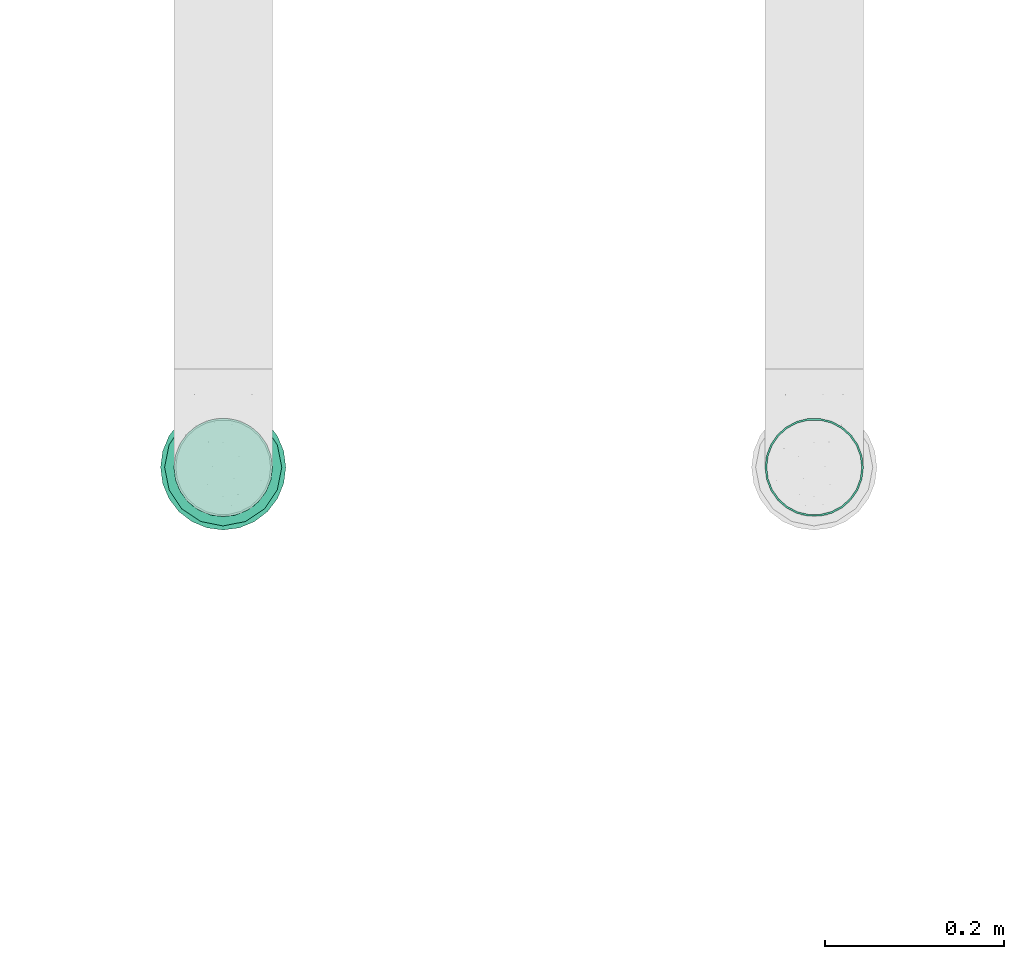
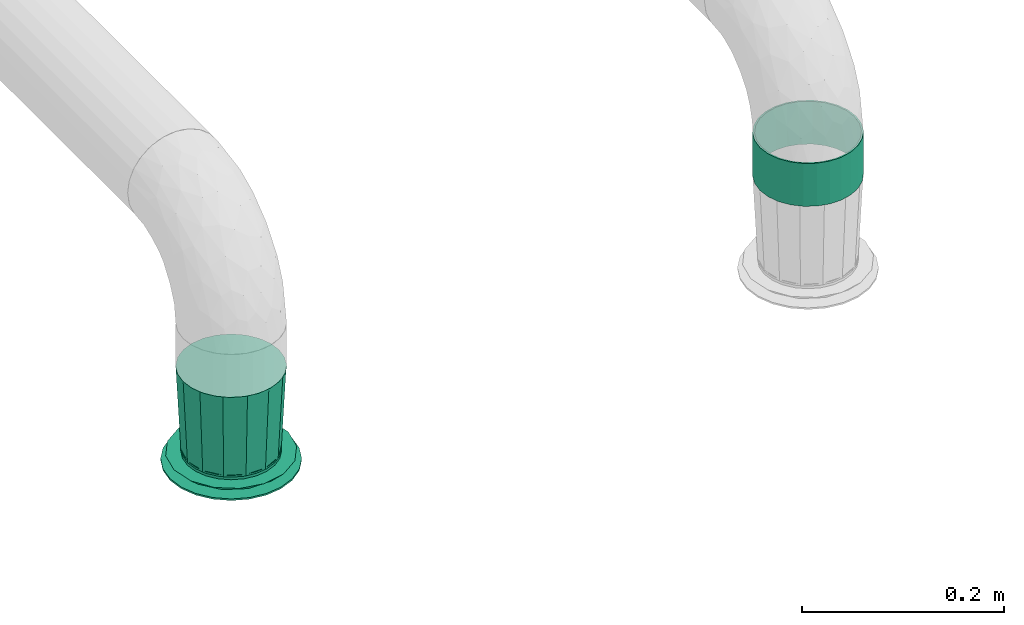
# One storey, part 48 of 115: 1 flow fitting, 1 flow segment, 1 flow terminal.
"""IFC2X3 building model written with IfcOpenShell, lengths in millimetres."""

from ifc_helpers import new_model, entity, si_unit, converted_unit, derived_unit, direction, frame, origin_with_axes, origin_2d_with_axis, place, context, subcontext, project, spatial, hollow_circle, extrude, open_shell, surface_model, source, transform, mapped, material, layer, layer_set, layer_usage, type_object, element, save


model = new_model("IFC2X3")

# Units and contexts
model_context = context("Model", 3, precision=1e-05, world=origin_with_axes(), true_north=direction((0.0, 1.0)))
body_context = subcontext(model_context, "Body", "Model", "MODEL_VIEW")
ifc_project = project(units=[si_unit("AREAUNIT", "SQUARE_METRE"), si_unit("VOLUMEUNIT", "CUBIC_METRE", prefix="DECI"), si_unit("TIMEUNIT", "SECOND"), si_unit("THERMODYNAMICTEMPERATUREUNIT", "DEGREE_CELSIUS"), si_unit("PRESSUREUNIT", "PASCAL"), si_unit("MASSUNIT", "GRAM", prefix="KILO"), si_unit("LENGTHUNIT", "METRE", prefix="MILLI"), si_unit("POWERUNIT", "WATT"), si_unit("ELECTRICCURRENTUNIT", "AMPERE"), si_unit("ELECTRICVOLTAGEUNIT", "VOLT"), derived_unit("VOLUMETRICFLOWRATEUNIT", [(si_unit("VOLUMEUNIT", "CUBIC_METRE", prefix="DECI"), 1), (si_unit("TIMEUNIT", "SECOND"), -1)]), derived_unit("LINEARVELOCITYUNIT", [(si_unit("LENGTHUNIT", "METRE"), 1), (si_unit("TIMEUNIT", "SECOND"), -1)]), derived_unit("MASSDENSITYUNIT", [(si_unit("MASSUNIT", "GRAM", prefix="KILO"), 1), (si_unit("VOLUMEUNIT", "CUBIC_METRE"), -1)]), converted_unit("PLANEANGLEUNIT", "DEGREE", entity("IfcRatioMeasure", 0.01745), si_unit("PLANEANGLEUNIT", "RADIAN"), dimensions=[0, 0, 0, 0, 0, 0, 0])], contexts=[model_context])

# Site, building, storey
site_placement = place(None, origin_with_axes())
site = spatial("IfcSite", under=ifc_project, at=site_placement, CompositionType="ELEMENT")
building_placement = place(site_placement, origin_with_axes())
building = spatial("IfcBuilding", under=site, at=building_placement, Name="mc-building", CompositionType="ELEMENT")
storey_placement = place(building_placement, frame((0.0, 0.0, 2950.0), z_axis=(0.0, 0.0, 1.0), x_axis=(1.0, 0.0, 0.0)))
storey = spatial("IfcBuildingStorey", under=building, at=storey_placement, Name="2. Korrus", CompositionType="ELEMENT", Elevation=2950.0)

# Flow terminal
air_terminal_type = type_object("IfcAirTerminalType", Name="100", PredefinedType="NOTDEFINED")
shared_shape_1 = source(origin_with_axes(), body_context, "Body", "SurfaceModel", [
    surface_model("IfcShellBasedSurfaceModel", [(11.2, 18.11733, -67.61481), (11.2, -18.11733, -67.61481), (11.2, 0.0, -70.0), (11.2, 67.61481, -18.11733), (11.2, 35.0, -60.62178), (11.2, 49.49747, -49.49747), (11.2, 60.62178, -35.0), (11.2, -67.61481, 18.11733), (11.2, -49.49747, -49.49747), (11.2, -67.61481, -18.11733), (11.2, -35.0, -60.62178), (11.2, -60.62178, -35.0), (11.2, -70.0, 0.0), (11.2, 18.11733, 67.61481), (11.2, 70.0, 0.0), (11.2, 67.61481, 18.11733), (11.2, 49.49747, 49.49747), (11.2, 60.62178, 35.0), (11.2, 35.0, 60.62178), (11.2, -49.49747, 49.49747), (11.2, -60.62178, 35.0), (11.2, -35.0, 60.62178), (11.2, -18.11733, 67.61481), (11.2, 0.0, 70.0), (9.2, 18.11733, 67.61481), (9.2, -67.61481, 18.11733), (9.2, 0.0, 70.0), (9.2, 49.49747, 49.49747), (9.2, 35.0, 60.62178), (9.2, 60.62178, 35.0), (9.2, 67.61481, 18.11733), (9.2, -35.0, 60.62178), (9.2, -49.49747, 49.49747), (9.2, -18.11733, 67.61481), (9.2, -60.62178, 35.0), (9.2, -67.61481, -18.11733), (9.2, -70.0, 0.0), (9.2, 67.61481, -18.11733), (9.2, 18.11733, -67.61481), (9.2, 49.49747, -49.49747), (9.2, 60.62178, -35.0), (9.2, 35.0, -60.62178), (9.2, -18.11733, -67.61481), (9.2, -49.49747, -49.49747), (9.2, -60.62178, -35.0), (9.2, -35.0, -60.62178), (9.2, 0.0, -70.0), (9.2, 70.0, 0.0), (9.2, 32.75, 0.0), (9.2, -16.375, 28.36233), (9.2, -28.36233, 16.375), (9.2, 16.375, 28.36233), (9.2, 0.0, 32.75), (9.2, 28.36233, 16.375), (9.2, -32.75, 0.0), (9.2, -16.375, -28.36233), (9.2, 16.375, -28.36233), (9.2, 0.0, -32.75), (9.2, 28.36233, -16.375), (9.2, -28.36233, -16.375), (6.2, -21.19625, -15.39997), (6.2, -21.19625, 15.39997), (6.2, 8.09625, 24.91768), (6.2, -8.09625, 24.91768), (6.2, -26.2, 0.0), (6.2, 21.19625, 15.39997), (6.2, -8.09625, -24.91768), (6.2, 21.19625, -15.39997), (6.2, 8.09625, -24.91768), (6.2, 26.2, 0.0), (9.2, 31.06579, -6.28555), (6.2, 23.69812, -7.69999), (6.2, -14.64625, -20.15883), (9.2, -22.36867, -22.36867), (6.2, -23.69812, -7.69999), (9.2, -31.06579, -6.28555), (6.2, 14.64625, -20.15883), (9.2, 8.1875, -30.55617), (6.2, 0.0, -24.91768), (9.2, 22.36867, -22.36867), (9.2, -8.1875, -30.55617), (9.2, -31.06579, 6.28555), (6.2, -23.69812, 7.69999), (6.2, 14.64625, 20.15883), (9.2, 22.36867, 22.36867), (6.2, 23.69812, 7.69999), (9.2, 31.06579, 6.28555), (6.2, -14.64625, 20.15883), (9.2, -8.1875, 30.55617), (6.2, 0.0, 24.91768), (9.2, -22.36867, 22.36867), (9.2, 8.1875, 30.55617), (6.2, -13.11761, 57.472), (6.2, -36.75472, 46.08897), (6.2, -53.11211, 25.57744), (6.2, 36.75472, 46.08897), (6.2, -58.95, 0.0), (6.2, 13.11761, 57.472), (6.2, 53.11211, 25.57744), (6.2, -53.11211, -25.57744), (6.2, -36.75472, -46.08897), (6.2, -13.11761, -57.472), (6.2, 58.95, 0.0), (6.2, 53.11211, -25.57744), (6.2, 13.11761, -57.472), (6.2, 36.75472, -46.08897), (0.0, -60.51411, 25.06576), (0.0, 0.0, 65.5), (0.0, 25.06576, 60.51411), (0.0, 46.3155, 46.3155), (0.0, 60.51411, 25.06576), (0.0, -46.3155, 46.3155), (0.0, -25.06576, 60.51411), (0.0, 0.0, -65.5), (0.0, -65.5, 0.0), (0.0, 65.5, 0.0), (0.0, 60.51411, -25.06576), (0.0, 46.3155, -46.3155), (0.0, 25.06576, -60.51411), (0.0, -46.3155, -46.3155), (0.0, -60.51411, -25.06576), (0.0, -25.06576, -60.51411), (6.2, 56.03105, -12.78872), (0.0, 53.4148, -35.69063), (0.0, 35.69063, -53.4148), (6.2, 24.93616, -51.78048), (0.0, -12.53288, -63.00706), (6.2, 0.0, -57.472), (0.0, -35.69063, -53.4148), (0.0, 63.00706, -12.53288), (6.2, 44.93342, -35.83321), (6.2, -24.93616, -51.78048), (6.2, -44.93342, -35.83321), (0.0, -53.4148, -35.69063), (0.0, 12.53288, -63.00706), (6.2, -56.03105, -12.78872), (0.0, -63.00706, -12.53288), (6.2, -56.03105, 12.78872), (0.0, -53.4148, 35.69063), (0.0, -35.69063, 53.4148), (6.2, -24.93616, 51.78048), (0.0, 12.53288, 63.00706), (6.2, 0.0, 57.472), (0.0, 35.69063, 53.4148), (0.0, -63.00706, 12.53288), (6.2, -44.93342, 35.83321), (6.2, 24.93616, 51.78048), (6.2, 44.93342, 35.83321), (0.0, 53.4148, 35.69063), (0.0, -12.53288, 63.00706), (6.2, 56.03105, 12.78872), (0.0, 63.00706, 12.53288), (-3.1, 12.94095, 48.29629), (-3.1, -35.35534, 35.35534), (-3.1, 0.0, 50.0), (-3.1, 35.35534, 35.35534), (-3.1, 25.0, 43.30127), (-3.1, -43.30127, 25.0), (-3.1, 43.30127, 25.0), (-3.1, -48.29629, -12.94095), (-3.1, -12.94095, 48.29629), (-3.1, -25.0, 43.30127), (-3.1, -50.0, 0.0), (-3.1, -48.29629, 12.94095), (-3.1, 48.29629, 12.94095), (-3.1, 12.94095, -48.29629), (-3.1, 50.0, 0.0), (-3.1, 48.29629, -12.94095), (-3.1, 35.35534, -35.35534), (-3.1, 43.30127, -25.0), (-3.1, 25.0, -43.30127), (-3.1, 0.0, -50.0), (-3.1, -35.35534, -35.35534), (-3.1, -43.30127, -25.0), (-3.1, -25.0, -43.30127), (-3.1, -12.94095, -48.29629), (0.0, 25.0, -43.30127), (0.0, 0.0, -50.0), (0.0, 12.94095, -48.29629), (0.0, 48.29629, -12.94095), (0.0, 35.35534, -35.35534), (0.0, -25.0, -43.30127), (0.0, 43.30127, -25.0), (0.0, -50.0, 0.0), (0.0, -12.94095, -48.29629), (0.0, -35.35534, -35.35534), (0.0, -48.29629, -12.94095), (0.0, -43.30127, -25.0), (0.0, 50.0, 0.0), (0.0, 43.30127, 25.0), (0.0, 12.94095, 48.29629), (0.0, 35.35534, 35.35534), (0.0, 25.0, 43.30127), (0.0, 0.0, 50.0), (0.0, -35.35534, 35.35534), (0.0, -43.30127, 25.0), (0.0, -48.29629, 12.94095), (0.0, -12.94095, 48.29629), (0.0, -25.0, 43.30127), (0.0, 48.29629, 12.94095), (-43.1, 0.0, 45.0), (-43.1, 11.64686, 43.46666), (-43.1, 22.5, 38.97115), (-43.1, -11.64686, 43.46666), (-43.1, 38.97115, 22.5), (-43.1, 43.46666, 11.64686), (-43.1, 31.81981, 31.81981), (-43.1, -22.5, 38.97115), (-43.1, -43.46666, 11.64686), (-43.1, -31.81981, 31.81981), (-43.1, -38.97115, 22.5), (-43.1, -45.0, 0.0), (-43.1, -43.46666, -11.64686), (-43.1, 45.0, 0.0), (-43.1, 43.46666, -11.64686), (-43.1, 38.97115, -22.5), (-43.1, 31.81981, -31.81981), (-43.1, 22.5, -38.97115), (-43.1, 11.64686, -43.46666), (-43.1, -31.81981, -31.81981), (-43.1, -38.97115, -22.5), (-43.1, -22.5, -38.97115), (-43.1, 0.0, -45.0), (-43.1, -11.64686, -43.46666), (-3.1, 22.5, -38.97115), (-3.1, 0.0, -45.0), (-3.1, 11.64686, -43.46666), (-3.1, 31.81981, -31.81981), (-3.1, -22.5, -38.97115), (-3.1, 38.97115, -22.5), (-3.1, 43.46666, -11.64686), (-3.1, 45.0, 0.0), (-3.1, -45.0, 0.0), (-3.1, -11.64686, -43.46666), (-3.1, -31.81981, -31.81981), (-3.1, -43.46666, -11.64686), (-3.1, -38.97115, -22.5), (-3.1, 0.0, 45.0), (-3.1, 43.46666, 11.64686), (-3.1, 38.97115, 22.5), (-3.1, 22.5, 38.97115), (-3.1, 31.81981, 31.81981), (-3.1, 11.64686, 43.46666), (-3.1, -11.64686, 43.46666), (-3.1, -43.46666, 11.64686), (-3.1, -31.81981, 31.81981), (-3.1, -38.97115, 22.5), (-3.1, -22.5, 38.97115)], [open_shell([[[0, 1, 2]], [[3, 0, 4]], [[5, 6, 3]], [[5, 3, 4]], [[7, 1, 0]], [[8, 7, 9]], [[10, 7, 8]], [[8, 9, 11]], [[12, 9, 7]], [[1, 7, 10]], [[7, 0, 3]], [[13, 14, 15]], [[16, 15, 17]], [[16, 18, 13]], [[16, 13, 15]], [[14, 13, 7]], [[7, 19, 20]], [[19, 7, 21]], [[7, 22, 21]], [[22, 7, 23]], [[7, 13, 23]], [[14, 7, 3]], [[24, 25, 26]], [[27, 24, 28]], [[27, 29, 30]], [[27, 30, 24]], [[25, 24, 30]], [[31, 25, 32]], [[25, 31, 33]], [[32, 25, 34]], [[33, 26, 25]], [[25, 35, 36]], [[25, 30, 37]], [[25, 37, 38]], [[39, 37, 40]], [[39, 41, 38]], [[39, 38, 37]], [[38, 42, 25]], [[35, 43, 44]], [[35, 25, 43]], [[45, 43, 25]], [[42, 45, 25]], [[38, 46, 42]], [[37, 30, 47]], [[35, 9, 36]], [[44, 11, 35]], [[10, 43, 45]], [[44, 43, 8]], [[1, 45, 42]], [[35, 11, 9]], [[9, 12, 36]], [[1, 10, 45]], [[8, 43, 10]], [[8, 11, 44]], [[2, 1, 42]], [[42, 46, 2]], [[38, 0, 46]], [[41, 4, 38]], [[6, 39, 40]], [[41, 39, 5]], [[3, 40, 37]], [[41, 5, 4]], [[4, 0, 38]], [[14, 3, 37]], [[6, 40, 3]], [[6, 5, 39]], [[47, 14, 37]], [[46, 0, 2]], [[30, 15, 47]], [[29, 17, 30]], [[18, 27, 28]], [[29, 27, 16]], [[13, 28, 24]], [[30, 17, 15]], [[15, 14, 47]], [[13, 18, 28]], [[16, 27, 18]], [[16, 17, 29]], [[23, 13, 24]], [[24, 26, 23]], [[33, 22, 26]], [[31, 21, 33]], [[20, 32, 34]], [[31, 32, 19]], [[7, 34, 25]], [[31, 19, 21]], [[21, 22, 33]], [[12, 7, 25]], [[20, 34, 7]], [[20, 19, 32]], [[36, 12, 25]], [[26, 22, 23]], [[48, 49, 50]], [[48, 51, 49]], [[49, 51, 52]], [[53, 51, 48]], [[48, 50, 54]], [[54, 55, 48]], [[56, 55, 57]], [[55, 58, 48]], [[58, 55, 56]], [[55, 54, 59]], [[60, 61, 62]], [[62, 61, 63]], [[64, 61, 60]], [[62, 65, 66]], [[67, 68, 65]], [[66, 60, 62]], [[65, 68, 66]], [[69, 67, 65]], [[69, 48, 70]], [[58, 71, 70]], [[72, 73, 60]], [[59, 74, 60]], [[75, 64, 74]], [[56, 68, 76]], [[72, 66, 55]], [[73, 72, 55]], [[68, 77, 78]], [[64, 75, 54]], [[59, 75, 74]], [[70, 71, 69]], [[67, 79, 76]], [[80, 55, 66]], [[68, 56, 77]], [[56, 76, 79]], [[79, 67, 58]], [[71, 58, 67]], [[80, 78, 57]], [[77, 57, 78]], [[66, 78, 80]], [[59, 60, 73]], [[64, 54, 81]], [[50, 82, 81]], [[83, 84, 65]], [[53, 85, 65]], [[86, 69, 85]], [[49, 63, 87]], [[83, 62, 51]], [[84, 83, 51]], [[63, 88, 89]], [[69, 86, 48]], [[53, 86, 85]], [[81, 82, 64]], [[61, 90, 87]], [[91, 51, 62]], [[63, 49, 88]], [[49, 87, 90]], [[90, 61, 50]], [[82, 50, 61]], [[91, 89, 52]], [[88, 52, 89]], [[62, 89, 91]], [[53, 65, 84]], [[92, 93, 94]], [[95, 94, 96]], [[97, 92, 95]], [[95, 92, 94]], [[96, 98, 95]], [[96, 99, 98]], [[99, 100, 101]], [[101, 102, 98]], [[102, 101, 103]], [[104, 105, 103]], [[101, 104, 103]], [[101, 98, 99]], [[106, 107, 108]], [[109, 110, 108]], [[106, 108, 110]], [[111, 112, 106]], [[106, 112, 107]], [[106, 113, 114]], [[106, 110, 113]], [[115, 116, 117]], [[117, 113, 110]], [[113, 117, 118]], [[114, 119, 120]], [[121, 119, 114]], [[121, 114, 113]], [[115, 117, 110]], [[103, 116, 122]], [[123, 116, 103]], [[124, 125, 118]], [[101, 126, 127]], [[100, 119, 128]], [[102, 122, 129]], [[103, 130, 123]], [[102, 129, 115]], [[113, 127, 126]], [[125, 124, 105]], [[130, 105, 117]], [[118, 125, 104]], [[124, 117, 105]], [[131, 100, 128]], [[119, 100, 132]], [[133, 99, 120]], [[134, 118, 104]], [[122, 116, 129]], [[127, 134, 104]], [[131, 121, 101]], [[99, 133, 132]], [[128, 121, 131]], [[130, 117, 123]], [[101, 121, 126]], [[99, 135, 120]], [[96, 136, 135]], [[136, 120, 135]], [[134, 127, 113]], [[133, 119, 132]], [[136, 96, 114]], [[94, 106, 137]], [[138, 106, 94]], [[139, 140, 112]], [[97, 141, 142]], [[95, 109, 143]], [[96, 137, 144]], [[94, 145, 138]], [[96, 144, 114]], [[107, 142, 141]], [[140, 139, 93]], [[145, 93, 111]], [[112, 140, 92]], [[139, 111, 93]], [[146, 95, 143]], [[109, 95, 147]], [[148, 98, 110]], [[149, 112, 92]], [[137, 106, 144]], [[142, 149, 92]], [[146, 108, 97]], [[98, 148, 147]], [[143, 108, 146]], [[145, 111, 138]], [[97, 108, 141]], [[98, 150, 110]], [[102, 151, 150]], [[151, 110, 150]], [[149, 142, 107]], [[148, 109, 147]], [[151, 102, 115]], [[152, 153, 154]], [[155, 152, 156]], [[157, 152, 158]], [[158, 152, 155]], [[158, 159, 157]], [[160, 153, 161]], [[160, 154, 153]], [[157, 162, 163]], [[153, 152, 157]], [[157, 159, 162]], [[158, 164, 159]], [[165, 166, 167]], [[168, 167, 169]], [[170, 165, 167]], [[170, 167, 168]], [[166, 165, 171]], [[159, 172, 173]], [[172, 159, 174]], [[174, 171, 175]], [[159, 164, 174]], [[166, 171, 174]], [[174, 164, 166]], [[176, 177, 178]], [[179, 176, 180]], [[176, 179, 181]], [[179, 180, 182]], [[179, 183, 181]], [[177, 181, 184]], [[177, 176, 181]], [[185, 186, 187]], [[186, 185, 181]], [[181, 183, 186]], [[183, 179, 188]], [[183, 188, 189]], [[190, 189, 191]], [[189, 190, 183]], [[190, 191, 192]], [[193, 194, 190]], [[183, 195, 196]], [[183, 190, 195]], [[194, 197, 198]], [[194, 195, 190]], [[197, 194, 193]], [[189, 188, 199]], [[164, 199, 166]], [[158, 189, 164]], [[192, 155, 156]], [[158, 155, 191]], [[190, 156, 152]], [[164, 189, 199]], [[199, 188, 166]], [[190, 192, 156]], [[191, 155, 192]], [[191, 189, 158]], [[193, 190, 152]], [[152, 154, 193]], [[160, 197, 154]], [[161, 198, 160]], [[195, 153, 157]], [[161, 153, 194]], [[196, 157, 163]], [[161, 194, 198]], [[198, 197, 160]], [[183, 196, 163]], [[195, 157, 196]], [[195, 194, 153]], [[162, 183, 163]], [[154, 197, 193]], [[159, 186, 162]], [[173, 187, 159]], [[181, 172, 174]], [[173, 172, 185]], [[184, 174, 175]], [[159, 187, 186]], [[186, 183, 162]], [[184, 181, 174]], [[185, 172, 181]], [[185, 187, 173]], [[177, 184, 175]], [[175, 171, 177]], [[165, 178, 171]], [[170, 176, 165]], [[182, 168, 169]], [[170, 168, 180]], [[179, 169, 167]], [[170, 180, 176]], [[176, 178, 165]], [[188, 179, 167]], [[182, 169, 179]], [[182, 180, 168]], [[166, 188, 167]], [[171, 178, 177]], [[200, 201, 202]], [[203, 200, 202]], [[204, 205, 202]], [[204, 202, 206]], [[203, 202, 205]], [[207, 208, 209]], [[207, 203, 205]], [[209, 208, 210]], [[211, 208, 212]], [[208, 207, 212]], [[207, 205, 212]], [[213, 214, 215]], [[205, 215, 212]], [[212, 216, 217]], [[216, 212, 215]], [[218, 219, 217]], [[212, 219, 220]], [[212, 217, 219]], [[221, 222, 223]], [[222, 221, 219]], [[218, 222, 219]], [[215, 205, 213]], [[224, 225, 226]], [[227, 228, 224]], [[229, 230, 231]], [[228, 227, 229]], [[229, 232, 228]], [[225, 228, 233]], [[225, 224, 228]], [[234, 235, 236]], [[235, 234, 228]], [[228, 232, 235]], [[232, 229, 231]], [[237, 238, 239]], [[240, 239, 241]], [[240, 242, 237]], [[240, 237, 239]], [[238, 237, 243]], [[244, 245, 246]], [[247, 244, 232]], [[244, 247, 245]], [[232, 238, 247]], [[238, 243, 247]], [[238, 232, 231]], [[205, 238, 213]], [[204, 239, 205]], [[240, 206, 202]], [[204, 206, 241]], [[242, 202, 201]], [[205, 239, 238]], [[238, 231, 213]], [[240, 202, 242]], [[241, 206, 240]], [[241, 239, 204]], [[201, 237, 242]], [[201, 200, 237]], [[243, 203, 207]], [[209, 247, 207]], [[246, 210, 208]], [[209, 210, 245]], [[244, 208, 211]], [[203, 243, 200]], [[207, 247, 243]], [[200, 243, 237]], [[209, 245, 247]], [[210, 246, 245]], [[244, 246, 208]], [[211, 232, 244]], [[212, 235, 211]], [[220, 236, 212]], [[228, 219, 221]], [[220, 219, 234]], [[233, 221, 223]], [[212, 236, 235]], [[235, 232, 211]], [[233, 228, 221]], [[234, 219, 228]], [[234, 236, 220]], [[225, 233, 223]], [[223, 222, 225]], [[226, 218, 217]], [[216, 224, 217]], [[229, 215, 214]], [[216, 215, 227]], [[230, 214, 213]], [[218, 226, 222]], [[217, 224, 226]], [[222, 226, 225]], [[216, 227, 224]], [[215, 229, 227]], [[230, 229, 214]], [[213, 231, 230]]])]),
])
flow_terminal_placement = place(storey_placement, frame((11458.64544, 8183.57591, 2200.0), z_axis=(0.0, 1.0, 0.0), x_axis=(0.0, 0.0, -1.0)))
element("IfcFlowTerminal", 1, at=flow_terminal_placement, inside=storey, type_object=air_terminal_type, Name="100", context=body_context, shape_type="MappedRepresentation", body=[
    mapped(shared_shape_1, transform((0.0, 0.0, 0.0), scale=1.0)),
])

# Flow segment
ifc_material = material(Name="FZ1")
ifc_layer = layer(ifc_material, 0.0)
ifc_layer_set = layer_set([ifc_layer], Name="FZ1")
ifc_layer_usage = layer_usage(ifc_layer_set, "AXIS1", "POSITIVE", 0.0)
duct_segment_type = type_object("IfcDuctSegmentType", PredefinedType="RIGIDSEGMENT")
shared_shape_2 = source(origin_with_axes(), body_context, "Body", "SweptSolid", [
    extrude(hollow_circle(Radius=55.0, WallThickness=2.0, at=origin_2d_with_axis()), frame((0.0, 0.0, 0.0), z_axis=(1.0, 0.0, 0.0), x_axis=(0.0, 1.0, 0.0)), (0.0, 0.0, 1.0), 51.9),
])
flow_segment_placement = place(storey_placement, frame((12119.2372, 8183.57591, 2355.0), z_axis=(0.0, 1.0, 0.0), x_axis=(0.0, 0.0, -1.0)))
element("IfcFlowSegment", 2, at=flow_segment_placement, inside=storey, type_object=duct_segment_type, material=ifc_layer_usage, context=body_context, shape_type="MappedRepresentation", body=[
    mapped(shared_shape_2, transform((0.0, 0.0, 0.0), scale=1.0)),
])

# Flow fitting
duct_fitting_type = type_object("IfcDuctFittingType", PredefinedType="TRANSITION")
shared_shape_3 = source(origin_with_axes(), body_context, "Body", "SurfaceModel", [
    surface_model("IfcShellBasedSurfaceModel", [(0.0, 12.94095, 48.29629), (0.0, -35.35534, 35.35534), (0.0, 0.0, 50.0), (0.0, 35.35534, 35.35534), (0.0, 25.0, 43.30127), (0.0, 43.30127, 25.0), (0.0, 48.29629, 12.94095), (0.0, -12.94095, 48.29629), (0.0, -25.0, 43.30127), (0.0, -48.29629, 12.94095), (0.0, -43.30127, 25.0), (0.0, -25.0, -43.30127), (0.0, -48.29629, -12.94095), (0.0, -50.0, 0.0), (0.0, 48.29629, -12.94095), (0.0, 12.94095, -48.29629), (0.0, 43.30127, -25.0), (0.0, 35.35534, -35.35534), (0.0, 25.0, -43.30127), (0.0, -35.35534, -35.35534), (0.0, -43.30127, -25.0), (0.0, -12.94095, -48.29629), (0.0, 0.0, -50.0), (0.0, 50.0, 0.0), (100.0, -55.0, 0.0), (100.0, -12.23865, 53.62104), (100.0, -34.29194, 43.00073), (100.0, 49.55329, -23.86361), (100.0, 12.23865, 53.62104), (100.0, 34.29194, 43.00073), (100.0, 55.0, 0.0), (100.0, 49.55329, 23.86361), (100.0, -49.55329, 23.86361), (100.0, 12.23865, -53.62104), (100.0, -49.55329, -23.86361), (100.0, -34.29194, -43.00073), (100.0, 34.29194, -43.00073), (100.0, -12.23865, -53.62104), (0.0, 11.12605, 48.7464), (0.0, -11.12605, 48.7464), (0.0, 31.17449, 39.09157), (0.0, -45.04844, -21.69419), (0.0, -45.04844, 21.69419), (0.0, -31.17449, 39.09157), (0.0, 45.04844, 21.69419), (0.0, 45.04844, -21.69419), (0.0, 31.17449, -39.09157), (0.0, -31.17449, -39.09157), (0.0, -11.12605, -48.7464), (0.0, 11.12605, -48.7464), (0.0, -47.52422, -10.84709), (100.0, -41.92261, -33.43217), (0.0, -38.11147, -30.39288), (100.0, 41.92261, -33.43217), (0.0, 38.11147, -30.39288), (0.0, -21.15027, -43.91899), (100.0, -23.2653, -48.31088), (100.0, -52.32388, -11.72483), (100.0, 0.0, -53.62104), (0.0, 0.0, -48.7464), (100.0, 23.2653, -48.31088), (0.0, 21.15027, -43.91899), (100.0, 52.32388, -11.72483), (0.0, 47.52422, -10.84709), (0.0, 47.52422, 10.84709), (100.0, 41.92261, 33.43217), (0.0, 38.11147, 30.39288), (100.0, -41.92261, 33.43217), (0.0, -38.11147, 30.39288), (0.0, 21.15027, 43.91899), (100.0, 23.2653, 48.31088), (100.0, 52.32388, 11.72483), (100.0, 0.0, 53.62104), (0.0, 0.0, 48.7464), (100.0, -23.2653, 48.31088), (0.0, -21.15027, 43.91899), (100.0, -52.32388, 11.72483), (0.0, -47.52422, 10.84709), (100.0, 27.5, -47.63139), (100.0, 0.0, -55.0), (100.0, 14.23505, -53.12592), (100.0, 38.89087, -38.89087), (100.0, -27.5, -47.63139), (100.0, 47.63139, -27.5), (100.0, 53.12592, -14.23505), (100.0, -14.23505, -53.12592), (100.0, -47.63139, -27.5), (100.0, -38.89087, -38.89087), (100.0, -53.12592, -14.23505), (100.0, 53.12592, 14.23505), (100.0, 47.63139, 27.5), (100.0, 27.5, 47.63139), (100.0, 38.89087, 38.89087), (100.0, 14.23505, 53.12592), (100.0, 0.0, 55.0), (100.0, -47.63139, 27.5), (100.0, -53.12592, 14.23505), (100.0, -27.5, 47.63139), (100.0, -38.89087, 38.89087), (100.0, -14.23505, 53.12592), (98.0, 0.0, 55.0), (98.0, 14.23505, 53.12592), (98.0, 27.5, 47.63139), (98.0, 38.89087, 38.89087), (98.0, 47.63139, 27.5), (98.0, -47.63139, 27.5), (98.0, 53.12592, -14.23505), (98.0, -27.5, 47.63139), (98.0, -14.23505, 53.12592), (98.0, -38.89087, 38.89087), (98.0, -55.0, 0.0), (98.0, -53.12592, 14.23505), (98.0, 53.12592, 14.23505), (98.0, 47.63139, -27.5), (98.0, -27.5, -47.63139), (98.0, 0.0, -55.0), (98.0, 38.89087, -38.89087), (98.0, 27.5, -47.63139), (98.0, 14.23505, -53.12592), (98.0, -47.63139, -27.5), (98.0, -38.89087, -38.89087), (98.0, -53.12592, -14.23505), (98.0, -14.23505, -53.12592), (98.0, 55.0, 0.0), (2.0, 12.94095, -48.29629), (2.0, 25.0, -43.30127), (2.0, 35.35534, -35.35534), (2.0, 43.30127, -25.0), (2.0, 48.29629, -12.94095), (2.0, 0.0, -50.0), (2.0, 50.0, 0.0), (2.0, -25.0, -43.30127), (2.0, -12.94095, -48.29629), (2.0, -35.35534, -35.35534), (2.0, -48.29629, -12.94095), (2.0, -43.30127, -25.0), (2.0, -48.29629, 12.94095), (2.0, 48.29629, 12.94095), (2.0, 43.30127, 25.0), (2.0, 35.35534, 35.35534), (2.0, -35.35534, 35.35534), (2.0, 12.94095, 48.29629), (2.0, 25.0, 43.30127), (2.0, 0.0, 50.0), (2.0, -43.30127, 25.0), (2.0, -50.0, 0.0), (2.0, -12.94095, 48.29629), (2.0, -25.0, 43.30127)], [open_shell([[[0, 1, 2]], [[3, 0, 4]], [[3, 5, 6]], [[0, 3, 1]], [[6, 1, 3]], [[7, 1, 8]], [[7, 2, 1]], [[1, 9, 10]], [[9, 1, 11]], [[12, 13, 9]], [[11, 1, 6]], [[6, 14, 11]], [[15, 14, 16]], [[17, 18, 15]], [[17, 15, 16]], [[11, 14, 15]], [[12, 19, 20]], [[19, 12, 11]], [[15, 21, 11]], [[12, 9, 11]], [[22, 21, 15]], [[14, 6, 23]], [[24, 25, 26]], [[25, 27, 28]], [[29, 28, 27]], [[27, 30, 31]], [[31, 29, 27]], [[24, 26, 32]], [[33, 24, 34]], [[33, 34, 35]], [[36, 27, 33]], [[33, 27, 24]], [[35, 37, 33]], [[24, 27, 25]], [[38, 23, 39]], [[40, 23, 38]], [[41, 42, 43]], [[41, 13, 42]], [[23, 43, 39]], [[40, 44, 23]], [[41, 23, 45]], [[41, 45, 46]], [[47, 41, 48]], [[49, 48, 41]], [[41, 46, 49]], [[23, 41, 43]], [[34, 50, 41]], [[47, 51, 52]], [[45, 27, 53]], [[36, 54, 53]], [[55, 48, 56]], [[34, 57, 50]], [[57, 13, 50]], [[13, 57, 24]], [[55, 35, 47]], [[35, 51, 47]], [[51, 41, 52]], [[58, 59, 49]], [[60, 61, 46]], [[37, 59, 58]], [[62, 63, 23]], [[35, 55, 56]], [[23, 30, 62]], [[53, 54, 45]], [[48, 37, 56]], [[33, 49, 61]], [[49, 33, 58]], [[54, 36, 46]], [[63, 27, 45]], [[34, 41, 51]], [[33, 61, 60]], [[48, 59, 37]], [[27, 63, 62]], [[46, 36, 60]], [[31, 64, 44]], [[40, 65, 66]], [[42, 32, 67]], [[26, 68, 67]], [[69, 38, 70]], [[31, 71, 64]], [[71, 23, 64]], [[23, 71, 30]], [[69, 29, 40]], [[29, 65, 40]], [[65, 44, 66]], [[72, 73, 39]], [[74, 75, 43]], [[28, 73, 72]], [[76, 77, 13]], [[29, 69, 70]], [[13, 24, 76]], [[67, 68, 42]], [[38, 28, 70]], [[25, 39, 75]], [[39, 25, 72]], [[68, 26, 43]], [[77, 32, 42]], [[31, 44, 65]], [[25, 75, 74]], [[38, 73, 28]], [[32, 77, 76]], [[43, 26, 74]], [[78, 79, 80]], [[81, 82, 78]], [[82, 83, 84]], [[81, 83, 82]], [[30, 82, 84]], [[79, 82, 85]], [[79, 78, 82]], [[82, 86, 87]], [[82, 30, 86]], [[24, 88, 86]], [[86, 30, 89]], [[90, 24, 89]], [[91, 90, 92]], [[91, 93, 94]], [[90, 91, 24]], [[94, 95, 91]], [[24, 95, 96]], [[24, 91, 95]], [[94, 97, 98]], [[98, 95, 94]], [[97, 94, 99]], [[89, 24, 86]], [[100, 101, 102]], [[100, 102, 103]], [[100, 104, 105]], [[104, 100, 103]], [[106, 105, 104]], [[100, 107, 108]], [[100, 109, 107]], [[105, 110, 111]], [[109, 100, 105]], [[105, 106, 110]], [[106, 104, 112]], [[106, 113, 110]], [[113, 114, 110]], [[115, 116, 117]], [[113, 116, 115]], [[117, 118, 115]], [[119, 114, 120]], [[121, 110, 119]], [[114, 115, 122]], [[119, 110, 114]], [[115, 114, 113]], [[123, 106, 112]], [[121, 88, 110]], [[119, 86, 121]], [[82, 120, 114]], [[119, 120, 87]], [[85, 114, 122]], [[121, 86, 88]], [[88, 24, 110]], [[85, 82, 114]], [[87, 120, 82]], [[87, 86, 119]], [[79, 85, 122]], [[122, 115, 79]], [[118, 80, 115]], [[117, 78, 118]], [[83, 116, 113]], [[117, 116, 81]], [[84, 113, 106]], [[117, 81, 78]], [[78, 80, 118]], [[30, 84, 106]], [[83, 113, 84]], [[83, 81, 116]], [[123, 30, 106]], [[115, 80, 79]], [[112, 89, 123]], [[104, 90, 112]], [[91, 103, 102]], [[104, 103, 92]], [[93, 102, 101]], [[112, 90, 89]], [[89, 30, 123]], [[93, 91, 102]], [[92, 103, 91]], [[92, 90, 104]], [[94, 93, 101]], [[101, 100, 94]], [[108, 99, 100]], [[107, 97, 108]], [[95, 109, 105]], [[107, 109, 98]], [[96, 105, 111]], [[107, 98, 97]], [[97, 99, 108]], [[24, 96, 111]], [[95, 105, 96]], [[95, 98, 109]], [[110, 24, 111]], [[100, 99, 94]], [[124, 125, 126]], [[124, 126, 127]], [[124, 128, 129]], [[128, 124, 127]], [[129, 128, 130]], [[129, 131, 132]], [[129, 130, 131]], [[133, 134, 135]], [[134, 133, 131]], [[131, 136, 134]], [[131, 130, 137]], [[137, 138, 139]], [[140, 137, 139]], [[140, 139, 141]], [[141, 139, 142]], [[140, 141, 143]], [[136, 140, 144]], [[145, 134, 136]], [[140, 146, 147]], [[131, 140, 136]], [[143, 146, 140]], [[131, 137, 140]], [[12, 134, 13]], [[20, 135, 12]], [[131, 19, 11]], [[20, 19, 133]], [[132, 11, 21]], [[12, 135, 134]], [[134, 145, 13]], [[132, 131, 11]], [[133, 19, 131]], [[133, 135, 20]], [[129, 132, 21]], [[21, 22, 129]], [[15, 124, 22]], [[18, 125, 15]], [[127, 17, 16]], [[18, 17, 126]], [[128, 16, 14]], [[18, 126, 125]], [[125, 124, 15]], [[130, 128, 14]], [[127, 16, 128]], [[127, 126, 17]], [[23, 130, 14]], [[22, 124, 129]], [[6, 137, 23]], [[5, 138, 6]], [[142, 3, 4]], [[5, 3, 139]], [[141, 4, 0]], [[6, 138, 137]], [[137, 130, 23]], [[141, 142, 4]], [[139, 3, 142]], [[139, 138, 5]], [[143, 141, 0]], [[0, 2, 143]], [[7, 146, 2]], [[8, 147, 7]], [[144, 1, 10]], [[8, 1, 140]], [[136, 10, 9]], [[8, 140, 147]], [[147, 146, 7]], [[145, 136, 9]], [[144, 10, 136]], [[144, 140, 1]], [[13, 145, 9]], [[2, 146, 143]]])]),
])
flow_fitting_placement = place(storey_placement, frame((11458.64544, 8183.57591, 2203.1), z_axis=(0.0, 1.0, 0.0), x_axis=(0.0, 0.0, 1.0)))
element("IfcFlowFitting", 3, at=flow_fitting_placement, inside=storey, type_object=duct_fitting_type, context=body_context, shape_type="MappedRepresentation", body=[
    mapped(shared_shape_3, transform((0.0, 0.0, 0.0), scale=1.0)),
])

save(model, "model.ifc")
